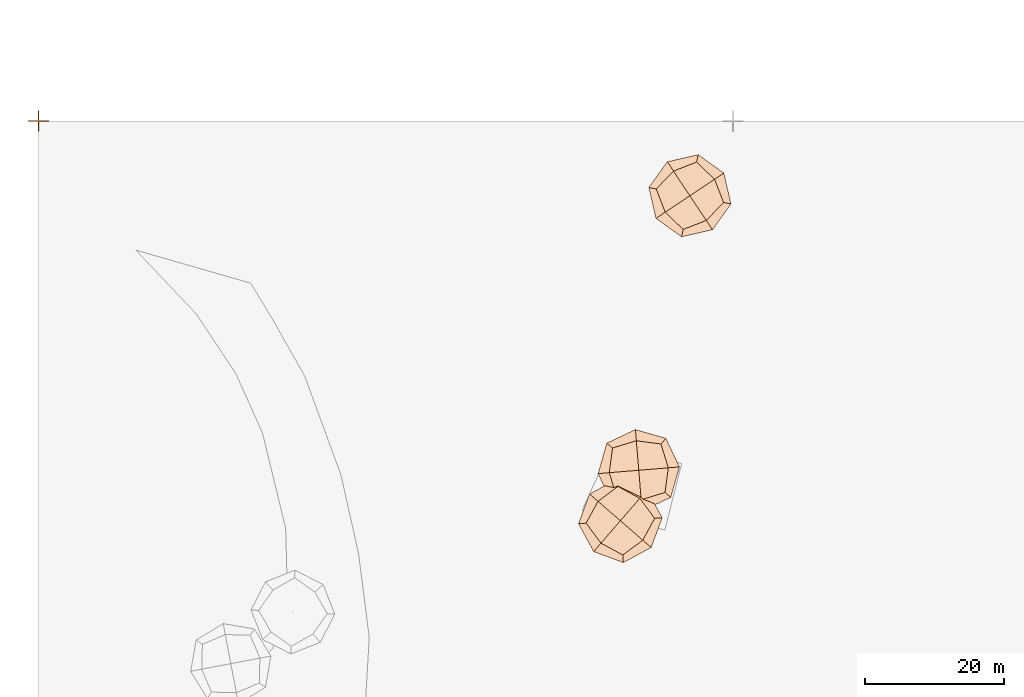
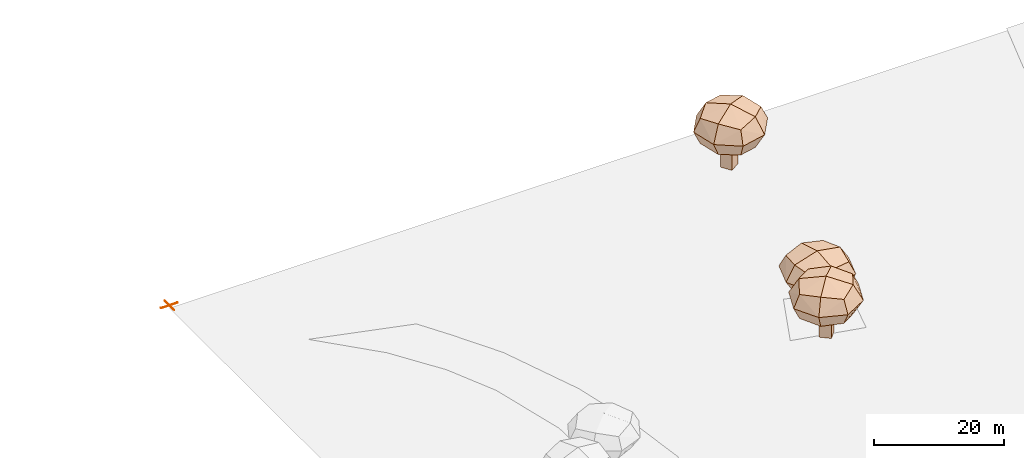
# Not in any storey, part 73 of 92: 3 geographic elements, 1 proxy.
"""IFC4 model written with IfcOpenShell, lengths in metres."""

from ifc_helpers import new_model, si_unit, origin_with_axes, place, context, subcontext, project, spatial, triangles, material, element, save


model = new_model("IFC4")

# Units and contexts
model_context = context("Model", 3, precision=1e-05, world=origin_with_axes())
body_context = subcontext(model_context, "Body", "Model", "MODEL_VIEW")
ifc_project = project(units=[si_unit("VOLUMEUNIT", "CUBIC_METRE"), si_unit("LENGTHUNIT", "METRE"), si_unit("AREAUNIT", "SQUARE_METRE")], contexts=[model_context])

# Site
site_placement = place(None, origin_with_axes())
site = spatial("IfcSite", under=ifc_project, at=site_placement)

# Proxy
proxy_placement = place(site_placement, origin_with_axes())
element("IfcBuildingElementProxy", 1, at=proxy_placement, inside=site, Name="CP1_Origin", ObjectType="Survey Control Point", context=body_context, shape_type="Tessellation", body=[
    triangles([(-1.5, -0.075, 0.0), (1.5, -0.075, 0.0), (1.5, 0.075, 0.0), (-1.5, 0.075, 0.0), (-0.075, -1.5, 0.0), (0.075, -1.5, 0.0), (0.075, 1.5, 0.0), (-0.075, 1.5, 0.0)], [[1, 2, 3], [1, 3, 4], [5, 6, 7], [5, 7, 8]], closed=False),
])

# Geographic elements
ifc_material = material(Name="tree")
geographic_element_1_placement = place(site_placement, origin_with_axes())
element("IfcGeographicElement", 2, at=geographic_element_1_placement, inside=site, material=ifc_material, Name="cw_instances_tree_0", context=body_context, shape_type="Tessellation", body=[
    triangles([(92.274878091013, -10.302522398242207, 6.749162418536442), (92.274878091013, -10.302522398242207, 6.749162418536442), (92.274878091013, -10.302522398242207, 6.749162418536442), (92.274878091013, -10.302522398242207, 0.0), (92.274878091013, -10.302522398242207, 0.0), (92.274878091013, -10.302522398242207, 0.0), (93.93964639189818, -9.19412422774216, 6.749162418536442), (93.93964639189818, -9.19412422774216, 6.749162418536442), (93.93964639189818, -9.19412422774216, 6.749162418536442), (93.93964639189818, -9.19412422774216, 0.0), (93.93964639189818, -9.19412422774216, 0.0), (93.93964639189818, -9.19412422774216, 0.0), (93.38327626151303, -11.967290699127393, 6.749162418536442), (93.38327626151303, -11.967290699127393, 6.749162418536442), (93.38327626151303, -11.967290699127393, 6.749162418536442), (93.38327626151303, -11.967290699127393, 0.0), (93.38327626151303, -11.967290699127393, 0.0), (93.38327626151303, -11.967290699127393, 0.0), (95.04804456239822, -10.858892528627347, 6.749162418536442), (95.04804456239822, -10.858892528627347, 6.749162418536442), (95.04804456239822, -10.858892528627347, 6.749162418536442), (95.04804456239822, -10.858892528627347, 0.0), (95.04804456239822, -10.858892528627347, 0.0), (95.04804456239822, -10.858892528627347, 0.0), (88.94627614886336, -9.814113544850345, 10.05331763230322), (88.94627614886336, -9.814113544850345, 10.05331763230322), (88.94627614886336, -9.814113544850345, 10.05331763230322), (88.94627614886336, -9.814113544850345, 10.05331763230322), (88.94627614886336, -9.814113544850345, 10.05331763230322), (88.94627614886336, -9.814113544850345, 10.05331763230322), (88.9462756163112, -9.81411361109371, 5.328904128304269), (88.9462756163112, -9.81411361109371, 5.328904128304269), (88.9462756163112, -9.81411361109371, 5.328904128304269), (88.9462756163112, -9.81411361109371, 5.328904128304269), (88.9462756163112, -9.81411361109371, 5.328904128304269), (88.9462756163112, -9.81411361109371, 5.328904128304269), (94.7729636788722, -5.9347206738404585, 10.05331763230322), (94.7729636788722, -5.9347206738404585, 10.05331763230322), (94.7729636788722, -5.9347206738404585, 10.05331763230322), (94.7729636788722, -5.9347206738404585, 10.05331763230322), (94.7729636788722, -5.9347206738404585, 10.05331763230322), (94.7729636788722, -5.9347206738404585, 10.05331763230322), (94.7729636788722, -5.9347206738404585, 5.328904128304269), (94.7729636788722, -5.9347206738404585, 5.328904128304269), (94.7729636788722, -5.9347206738404585, 5.328904128304269), (94.7729636788722, -5.9347206738404585, 5.328904128304269), (94.7729636788722, -5.9347206738404585, 5.328904128304269), (94.7729636788722, -5.9347206738404585, 5.328904128304269), (92.82566895258779, -15.64080227297131, 10.05331763230322), (92.82566895258779, -15.64080227297131, 10.05331763230322), (92.82566895258779, -15.64080227297131, 10.05331763230322), (92.82566895258779, -15.64080227297131, 10.05331763230322), (92.82566895258779, -15.64080227297131, 10.05331763230322), (92.82566895258779, -15.64080227297131, 10.05331763230322), (92.82566868657223, -15.640801873426918, 5.328904128304269), (92.82566868657223, -15.640801873426918, 5.328904128304269), (92.82566868657223, -15.640801873426918, 5.328904128304269), (92.82566868657223, -15.640801873426918, 5.328904128304269), (92.82566868657223, -15.640801873426918, 5.328904128304269), (92.82566868657223, -15.640801873426918, 5.328904128304269), (98.652357214921, -11.76140920271028, 10.05331763230322), (98.652357214921, -11.76140920271028, 10.05331763230322), (98.652357214921, -11.76140920271028, 10.05331763230322), (98.652357214921, -11.76140920271028, 10.05331763230322), (98.652357214921, -11.76140920271028, 10.05331763230322), (98.652357214921, -11.76140920271028, 10.05331763230322), (98.6523570151488, -11.76140933571806, 5.328904128304269), (98.6523570151488, -11.76140933571806, 5.328904128304269), (98.6523570151488, -11.76140933571806, 5.328904128304269), (98.6523570151488, -11.76140933571806, 5.328904128304269), (98.6523570151488, -11.76140933571806, 5.328904128304269), (98.6523570151488, -11.76140933571806, 5.328904128304269), (96.16406989531386, -14.339523496722784, 4.811260820074589), (96.16406989531386, -14.339523496722784, 4.811260820074589), (96.16406989531386, -14.339523496722784, 4.811260820074589), (96.16406989531386, -14.339523496722784, 4.811260820074589), (90.2475546893059, -13.152514584506985, 4.811260820074589), (90.2475546893059, -13.152514584506985, 4.811260820074589), (90.2475546893059, -13.152514584506985, 4.811260820074589), (90.2475546893059, -13.152514584506985, 4.811260820074589), (87.88280150196444, -9.600752906727205, 7.6911112852535135), (87.88280150196444, -9.600752906727205, 7.6911112852535135), (87.88280150196444, -9.600752906727205, 7.6911112852535135), (87.88280150196444, -9.600752906727205, 7.6911112852535135), (99.71583158974133, -11.974770298297335, 7.6911112852535135), (99.71583158974133, -11.974770298297335, 7.6911112852535135), (99.71583158974133, -11.974770298297335, 7.6911112852535135), (99.71583158974133, -11.974770298297335, 7.6911112852535135), (94.98632504653786, -4.871245841556212, 7.6911112852535135), (94.98632504653786, -4.871245841556212, 7.6911112852535135), (94.98632504653786, -4.871245841556212, 7.6911112852535135), (94.98632504653786, -4.871245841556212, 7.6911112852535135), (92.61230790989931, -16.704276312229815, 7.6911112852535135), (92.61230790989931, -16.704276312229815, 7.6911112852535135), (92.61230790989931, -16.704276312229815, 7.6911112852535135), (92.61230790989931, -16.704276312229815, 7.6911112852535135), (97.3510784943529, -8.423007910556542, 10.57096053558313), (97.3510784943529, -8.423007910556542, 10.57096053558313), (97.3510784943529, -8.423007910556542, 10.57096053558313), (97.3510784943529, -8.423007910556542, 10.57096053558313), (91.43456287765143, -7.2359993558751405, 10.570962121636393), (91.43456287765143, -7.2359993558751405, 10.570962121636393), (91.43456287765143, -7.2359993558751405, 10.570962121636393), (91.43456287765143, -7.2359993558751405, 10.570962121636393), (97.3510781308423, -8.423008212649322, 4.811260820074589), (97.3510781308423, -8.423008212649322, 4.811260820074589), (97.3510781308423, -8.423008212649322, 4.811260820074589), (97.3510781308423, -8.423008212649322, 4.811260820074589), (96.1640698620185, -14.339523518890747, 10.57096053558313), (96.1640698620185, -14.339523518890747, 10.57096053558313), (96.1640698620185, -14.339523518890747, 10.57096053558313), (96.1640698620185, -14.339523518890747, 10.57096053558313), (90.24755467267993, -13.152514559535462, 10.570962121636393), (90.24755467267993, -13.152514559535462, 10.570962121636393), (90.24755467267993, -13.152514559535462, 10.570962121636393), (90.24755467267993, -13.152514559535462, 10.570962121636393), (91.43456318806805, -7.235999713843746, 4.811260820074589), (91.43456318806805, -7.235999713843746, 4.811260820074589), (91.43456318806805, -7.235999713843746, 4.811260820074589), (91.43456318806805, -7.235999713843746, 4.811260820074589), (93.7993163115355, -10.78776153026014, 11.657286177333468), (93.7993163115355, -10.78776153026014, 11.657286177333468), (93.7993163115355, -10.78776153026014, 11.657286177333468), (93.7993163115355, -10.78776153026014, 11.657286177333468), (93.7993163115355, -10.78776153026014, 11.657286177333468), (93.7993163115355, -10.78776153026014, 11.657286177333468), (93.7993163115355, -10.78776153026014, 11.657286177333468), (93.7993163115355, -10.78776153026014, 11.657286177333468), (98.6908570869542, -7.530986996820504, 7.6911112852535135), (98.6908570869542, -7.530986996820504, 7.6911112852535135), (98.6908570869542, -7.530986996820504, 7.6911112852535135), (98.6908570869542, -7.530986996820504, 7.6911112852535135), (98.6908570869542, -7.530986996820504, 7.6911112852535135), (98.6908570869542, -7.530986996820504, 7.6911112852535135), (98.6908570869542, -7.530986996820504, 7.6911112852535135), (98.6908570869542, -7.530986996820504, 7.6911112852535135), (97.05609078407838, -15.679302105950047, 7.6911112852535135), (97.05609078407838, -15.679302105950047, 7.6911112852535135), (97.05609078407838, -15.679302105950047, 7.6911112852535135), (97.05609078407838, -15.679302105950047, 7.6911112852535135), (97.05609078407838, -15.679302105950047, 7.6911112852535135), (97.05609078407838, -15.679302105950047, 7.6911112852535135), (97.05609078407838, -15.679302105950047, 7.6911112852535135), (97.05609078407838, -15.679302105950047, 7.6911112852535135), (93.79931623394764, -10.787761413726358, 3.724937169327284), (93.79931623394764, -10.787761413726358, 3.724937169327284), (93.79931623394764, -10.787761413726358, 3.724937169327284), (93.79931623394764, -10.787761413726358, 3.724937169327284), (93.79931623394764, -10.787761413726358, 3.724937169327284), (93.79931623394764, -10.787761413726358, 3.724937169327284), (93.79931623394764, -10.787761413726358, 3.724937169327284), (93.79931623394764, -10.787761413726358, 3.724937169327284), (90.54254216612208, -5.896221193288338, 7.6911112852535135), (90.54254216612208, -5.896221193288338, 7.6911112852535135), (90.54254216612208, -5.896221193288338, 7.6911112852535135), (90.54254216612208, -5.896221193288338, 7.6911112852535135), (90.54254216612208, -5.896221193288338, 7.6911112852535135), (90.54254216612208, -5.896221193288338, 7.6911112852535135), (90.54254216612208, -5.896221193288338, 7.6911112852535135), (90.54254216612208, -5.896221193288338, 7.6911112852535135), (88.90777572487018, -14.044535805877793, 7.6911112852535135), (88.90777572487018, -14.044535805877793, 7.6911112852535135), (88.90777572487018, -14.044535805877793, 7.6911112852535135), (88.90777572487018, -14.044535805877793, 7.6911112852535135), (88.90777572487018, -14.044535805877793, 7.6911112852535135), (88.90777572487018, -14.044535805877793, 7.6911112852535135), (88.90777572487018, -14.044535805877793, 7.6911112852535135), (88.90777572487018, -14.044535805877793, 7.6911112852535135)], [[15, 8, 2], [7, 24, 11], [19, 16, 22], [4, 23, 17], [3, 12, 6], [14, 5, 18], [26, 127, 101], [54, 123, 114], [124, 66, 98], [128, 38, 102], [45, 133, 108], [40, 135, 89], [130, 63, 88], [131, 70, 105], [68, 141, 73], [61, 140, 86], [137, 49, 93], [142, 56, 74], [59, 145, 75], [31, 149, 79], [150, 43, 107], [146, 71, 76], [35, 154, 120], [30, 157, 83], [158, 42, 91], [153, 47, 119], [58, 164, 77], [51, 162, 96], [167, 28, 81], [165, 33, 80], [15, 21, 8], [7, 20, 24], [19, 13, 16], [4, 10, 23], [3, 9, 12], [14, 1, 5], [25, 115, 126], [53, 111, 121], [122, 112, 65], [125, 99, 37], [46, 90, 136], [39, 100, 134], [132, 97, 64], [129, 87, 69], [67, 85, 138], [62, 110, 144], [143, 109, 50], [139, 94, 55], [60, 78, 147], [32, 117, 151], [152, 118, 44], [148, 106, 72], [36, 84, 160], [29, 104, 156], [155, 103, 41], [159, 92, 48], [57, 95, 161], [52, 113, 163], [166, 116, 27], [168, 82, 34]], closed=True),
])
geographic_element_2_placement = place(site_placement, origin_with_axes())
element("IfcGeographicElement", 3, at=geographic_element_2_placement, inside=site, material=ifc_material, Name="cw_instances_tree_63", context=body_context, shape_type="Tessellation", body=[
    triangles([(83.85068214677291, -55.99029793161618, 6.435480642457017), (83.85068214677291, -55.99029793161618, 6.435480642457017), (83.85068214677291, -55.99029793161618, 6.435480642457017), (83.85068214677291, -55.99029793161618, 0.0), (83.85068214677291, -55.99029793161618, 0.0), (83.85068214677291, -55.99029793161618, 0.0), (85.36123295008736, -57.301113048482826, 6.435480642457017), (85.36123295008736, -57.301113048482826, 6.435480642457017), (85.36123295008736, -57.301113048482826, 6.435480642457017), (85.36123295008736, -57.301113048482826, 0.0), (85.36123295008736, -57.301113048482826, 0.0), (85.36123295008736, -57.301113048482826, 0.0), (82.53986702990628, -57.50084873493062, 6.435480642457017), (82.53986702990628, -57.50084873493062, 6.435480642457017), (82.53986702990628, -57.50084873493062, 6.435480642457017), (82.53986702990628, -57.50084873493062, 0.0), (82.53986702990628, -57.50084873493062, 0.0), (82.53986702990628, -57.50084873493062, 0.0), (84.0504178332207, -58.81166385179726, 6.435480642457017), (84.0504178332207, -58.81166385179726, 6.435480642457017), (84.0504178332207, -58.81166385179726, 6.435480642457017), (84.0504178332207, -58.81166385179726, 0.0), (84.0504178332207, -58.81166385179726, 0.0), (84.0504178332207, -58.81166385179726, 0.0), (83.43798136130964, -52.6514639796156, 9.586068167135462), (83.43798136130964, -52.6514639796156, 9.586068167135462), (83.43798136130964, -52.6514639796156, 9.586068167135462), (83.43798136130964, -52.6514639796156, 9.586068167135462), (83.43798136130964, -52.6514639796156, 9.586068167135462), (83.43798136130964, -52.6514639796156, 9.586068167135462), (83.43798115607527, -52.65146348375388, 5.08123189760902), (83.43798115607527, -52.65146348375388, 5.08123189760902), (83.43798115607527, -52.65146348375388, 5.08123189760902), (83.43798115607527, -52.65146348375388, 5.08123189760902), (83.43798115607527, -52.65146348375388, 5.08123189760902), (83.43798115607527, -52.65146348375388, 5.08123189760902), (88.72490806889806, -57.23931561285213, 9.586068167135462), (88.72490806889806, -57.23931561285213, 9.586068167135462), (88.72490806889806, -57.23931561285213, 9.586068167135462), (88.72490806889806, -57.23931561285213, 9.586068167135462), (88.72490806889806, -57.23931561285213, 9.586068167135462), (88.72490806889806, -57.23931561285213, 9.586068167135462), (88.72490806889806, -57.23931561285213, 5.08123189760902), (88.72490806889806, -57.23931561285213, 5.08123189760902), (88.72490806889806, -57.23931561285213, 5.08123189760902), (88.72490806889806, -57.23931561285213, 5.08123189760902), (88.72490806889806, -57.23931561285213, 5.08123189760902), (88.72490806889806, -57.23931561285213, 5.08123189760902), (78.85012855508357, -57.938390940374966, 9.586068167135462), (78.85012855508357, -57.938390940374966, 9.586068167135462), (78.85012855508357, -57.938390940374966, 9.586068167135462), (78.85012855508357, -57.938390940374966, 9.586068167135462), (78.85012855508357, -57.938390940374966, 9.586068167135462), (78.85012855508357, -57.938390940374966, 9.586068167135462), (78.8501288696792, -57.938390577842775, 5.08123189760902), (78.8501288696792, -57.938390577842775, 5.08123189760902), (78.8501288696792, -57.938390577842775, 5.08123189760902), (78.8501288696792, -57.938390577842775, 5.08123189760902), (78.8501288696792, -57.938390577842775, 5.08123189760902), (78.8501288696792, -57.938390577842775, 5.08123189760902), (84.13705564917247, -62.52624322677104, 9.586068167135462), (84.13705564917247, -62.52624322677104, 9.586068167135462), (84.13705564917247, -62.52624322677104, 9.586068167135462), (84.13705564917247, -62.52624322677104, 9.586068167135462), (84.13705564917247, -62.52624322677104, 9.586068167135462), (84.13705564917247, -62.52624322677104, 9.586068167135462), (84.13705546790638, -62.526243069473225, 5.08123189760902), (84.13705546790638, -62.526243069473225, 5.08123189760902), (84.13705546790638, -62.526243069473225, 5.08123189760902), (84.13705546790638, -62.526243069473225, 5.08123189760902), (84.13705546790638, -62.526243069473225, 5.08123189760902), (84.13705546790638, -62.526243069473225, 5.08123189760902), (80.99091095376036, -60.81159438416813, 4.587647170612347), (80.99091095376036, -60.81159438416813, 4.587647170612347), (80.99091095376036, -60.81159438416813, 4.587647170612347), (80.99091095376036, -60.81159438416813, 4.587647170612347), (80.56477776146801, -54.79224617667673, 4.587647170612347), (80.56477776146801, -54.79224617667673, 4.587647170612347), (80.56477776146801, -54.79224617667673, 4.587647170612347), (80.56477776146801, -54.79224617667673, 4.587647170612347), (83.36138489067983, -51.56950553901625, 7.3336504185011036), (83.36138489067983, -51.56950553901625, 7.3336504185011036), (83.36138489067983, -51.56950553901625, 7.3336504185011036), (83.36138489067983, -51.56950553901625, 7.3336504185011036), (84.21365160652634, -63.6082015264881, 7.3336504185011036), (84.21365160652634, -63.6082015264881, 7.3336504185011036), (84.21365160652634, -63.6082015264881, 7.3336504185011036), (84.21365160652634, -63.6082015264881, 7.3336504185011036), (89.80686688189107, -57.162719796380536, 7.3336504185011036), (89.80686688189107, -57.162719796380536, 7.3336504185011036), (89.80686688189107, -57.162719796380536, 7.3336504185011036), (89.80686688189107, -57.162719796380536, 7.3336504185011036), (77.76817059293174, -58.01498685965374, 7.3336504185011036), (77.76817059293174, -58.01498685965374, 7.3336504185011036), (77.76817059293174, -58.01498685965374, 7.3336504185011036), (77.76817059293174, -58.01498685965374, 7.3336504185011036), (87.01025944463768, -60.385460789020456, 10.079652508003273), (87.01025944463768, -60.385460789020456, 10.079652508003273), (87.01025944463768, -60.385460789020456, 10.079652508003273), (87.01025944463768, -60.385460789020456, 10.079652508003273), (86.5841257986181, -54.366112280478255, 10.079654020341316), (86.5841257986181, -54.366112280478255, 10.079654020341316), (86.5841257986181, -54.366112280478255, 10.079654020341316), (86.5841257986181, -54.366112280478255, 10.079654020341316), (87.01025905688788, -60.385460518742676, 4.587647170612347), (87.01025905688788, -60.385460518742676, 4.587647170612347), (87.01025905688788, -60.385460518742676, 4.587647170612347), (87.01025905688788, -60.385460518742676, 4.587647170612347), (80.99091092354934, -60.811594357951826, 10.079652508003273), (80.99091092354934, -60.811594357951826, 10.079652508003273), (80.99091092354934, -60.811594357951826, 10.079652508003273), (80.99091092354934, -60.811594357951826, 10.079652508003273), (80.56477778113023, -54.79224615401847, 10.079654020341316), (80.56477778113023, -54.79224615401847, 10.079654020341316), (80.56477778113023, -54.79224615401847, 10.079654020341316), (80.56477778113023, -54.79224615401847, 10.079654020341316), (86.58412553589307, -54.36611267478215, 4.587647170612347), (86.58412553589307, -54.36611267478215, 4.587647170612347), (86.58412553589307, -54.36611267478215, 4.587647170612347), (86.58412553589307, -54.36611267478215, 4.587647170612347), (83.78751825606284, -57.58885328766168, 11.115488839292068), (83.78751825606284, -57.58885328766168, 11.115488839292068), (83.78751825606284, -57.58885328766168, 11.115488839292068), (83.78751825606284, -57.58885328766168, 11.115488839292068), (83.78751825606284, -57.58885328766168, 11.115488839292068), (83.78751825606284, -57.58885328766168, 11.115488839292068), (83.78751825606284, -57.58885328766168, 11.115488839292068), (83.78751825606284, -57.58885328766168, 11.115488839292068), (88.22592629043315, -61.44038358608614, 7.3336504185011036), (88.22592629043315, -61.44038358608614, 7.3336504185011036), (88.22592629043315, -61.44038358608614, 7.3336504185011036), (88.22592629043315, -61.44038358608614, 7.3336504185011036), (88.22592629043315, -61.44038358608614, 7.3336504185011036), (88.22592629043315, -61.44038358608614, 7.3336504185011036), (88.22592629043315, -61.44038358608614, 7.3336504185011036), (88.22592629043315, -61.44038358608614, 7.3336504185011036), (79.93598813403642, -62.02726121030136, 7.3336504185011036), (79.93598813403642, -62.02726121030136, 7.3336504185011036), (79.93598813403642, -62.02726121030136, 7.3336504185011036), (79.93598813403642, -62.02726121030136, 7.3336504185011036), (79.93598813403642, -62.02726121030136, 7.3336504185011036), (79.93598813403642, -62.02726121030136, 7.3336504185011036), (79.93598813403642, -62.02726121030136, 7.3336504185011036), (79.93598813403642, -62.02726121030136, 7.3336504185011036), (83.7875183478199, -57.58885318192312, 3.551812737790455), (83.7875183478199, -57.58885318192312, 3.551812737790455), (83.7875183478199, -57.58885318192312, 3.551812737790455), (83.7875183478199, -57.58885318192312, 3.551812737790455), (83.7875183478199, -57.58885318192312, 3.551812737790455), (83.7875183478199, -57.58885318192312, 3.551812737790455), (83.7875183478199, -57.58885318192312, 3.551812737790455), (83.7875183478199, -57.58885318192312, 3.551812737790455), (87.63904823477294, -53.150445743783706, 7.3336504185011036), (87.63904823477294, -53.150445743783706, 7.3336504185011036), (87.63904823477294, -53.150445743783706, 7.3336504185011036), (87.63904823477294, -53.150445743783706, 7.3336504185011036), (87.63904823477294, -53.150445743783706, 7.3336504185011036), (87.63904823477294, -53.150445743783706, 7.3336504185011036), (87.63904823477294, -53.150445743783706, 7.3336504185011036), (87.63904823477294, -53.150445743783706, 7.3336504185011036), (79.34911052036998, -53.737323102779186, 7.3336504185011036), (79.34911052036998, -53.737323102779186, 7.3336504185011036), (79.34911052036998, -53.737323102779186, 7.3336504185011036), (79.34911052036998, -53.737323102779186, 7.3336504185011036), (79.34911052036998, -53.737323102779186, 7.3336504185011036), (79.34911052036998, -53.737323102779186, 7.3336504185011036), (79.34911052036998, -53.737323102779186, 7.3336504185011036), (79.34911052036998, -53.737323102779186, 7.3336504185011036)], [[15, 8, 2], [7, 24, 11], [19, 16, 22], [4, 23, 17], [3, 12, 6], [14, 5, 18], [26, 127, 101], [54, 123, 114], [124, 66, 98], [128, 38, 102], [45, 133, 108], [40, 135, 89], [130, 63, 88], [131, 70, 105], [68, 141, 73], [61, 140, 86], [137, 49, 93], [142, 56, 74], [59, 145, 75], [31, 149, 79], [150, 43, 107], [146, 71, 76], [35, 154, 120], [30, 157, 83], [158, 42, 91], [153, 47, 119], [58, 164, 77], [51, 162, 96], [167, 28, 81], [165, 33, 80], [15, 21, 8], [7, 20, 24], [19, 13, 16], [4, 10, 23], [3, 9, 12], [14, 1, 5], [25, 115, 126], [53, 111, 121], [122, 112, 65], [125, 99, 37], [46, 90, 136], [39, 100, 134], [132, 97, 64], [129, 87, 69], [67, 85, 138], [62, 110, 144], [143, 109, 50], [139, 94, 55], [60, 78, 147], [32, 117, 151], [152, 118, 44], [148, 106, 72], [36, 84, 160], [29, 104, 156], [155, 103, 41], [159, 92, 48], [57, 95, 161], [52, 113, 163], [166, 116, 27], [168, 82, 34]], closed=True),
])
geographic_element_3_placement = place(site_placement, origin_with_axes())
element("IfcGeographicElement", 4, at=geographic_element_3_placement, inside=site, material=ifc_material, Name="cw_instances_tree_64", context=body_context, shape_type="Tessellation", body=[
    triangles([(87.59801395692567, -49.218886108406636, 6.105379025582397), (87.59801395692567, -49.218886108406636, 6.105379025582397), (87.59801395692567, -49.218886108406636, 6.105379025582397), (87.59801395692567, -49.218886108406636, 0.0), (87.59801395692567, -49.218886108406636, 0.0), (87.59801395692567, -49.218886108406636, 0.0), (87.76233868025686, -51.212124023283366, 6.105379025582397), (87.76233868025686, -51.212124023283366, 6.105379025582397), (87.76233868025686, -51.212124023283366, 6.105379025582397), (87.76233868025686, -51.212124023283366, 0.0), (87.76233868025686, -51.212124023283366, 0.0), (87.76233868025686, -51.212124023283366, 0.0), (85.60477604204894, -49.38321083173783, 6.105379025582397), (85.60477604204894, -49.38321083173783, 6.105379025582397), (85.60477604204894, -49.38321083173783, 6.105379025582397), (85.60477604204894, -49.38321083173783, 0.0), (85.60477604204894, -49.38321083173783, 0.0), (85.60477604204894, -49.38321083173783, 0.0), (85.76910076538013, -51.37644874661455, 6.105379025582397), (85.76910076538013, -51.37644874661455, 6.105379025582397), (85.76910076538013, -51.37644874661455, 6.105379025582397), (85.76910076538013, -51.37644874661455, 0.0), (85.76910076538013, -51.37644874661455, 0.0), (85.76910076538013, -51.37644874661455, 0.0), (89.63624843385455, -46.54237077790462, 9.094360278129429), (89.63624843385455, -46.54237077790462, 9.094360278129429), (89.63624843385455, -46.54237077790462, 9.094360278129429), (89.63624843385455, -46.54237077790462, 9.094360278129429), (89.63624843385455, -46.54237077790462, 9.094360278129429), (89.63624843385455, -46.54237077790462, 9.094360278129429), (89.63624863360516, -46.54237027980856, 4.820595131172373), (89.63624863360516, -46.54237027980856, 4.820595131172373), (89.63624863360516, -46.54237027980856, 4.820595131172373), (89.63624863360516, -46.54237027980856, 4.820595131172373), (89.63624863360516, -46.54237027980856, 4.820595131172373), (89.63624863360516, -46.54237027980856, 4.820595131172373), (90.21138506749112, -53.51870179590055, 9.094360278129429), (90.21138506749112, -53.51870179590055, 9.094360278129429), (90.21138506749112, -53.51870179590055, 9.094360278129429), (90.21138506749112, -53.51870179590055, 9.094360278129429), (90.21138506749112, -53.51870179590055, 9.094360278129429), (90.21138506749112, -53.51870179590055, 9.094360278129429), (90.21138506749112, -53.51870179590055, 4.820595131172373), (90.21138506749112, -53.51870179590055, 4.820595131172373), (90.21138506749112, -53.51870179590055, 4.820595131172373), (90.21138506749112, -53.51870179590055, 4.820595131172373), (90.21138506749112, -53.51870179590055, 4.820595131172373), (90.21138506749112, -53.51870179590055, 4.820595131172373), (82.65991639994753, -47.11750677285141, 9.094360278129429), (82.65991639994753, -47.11750677285141, 9.094360278129429), (82.65991639994753, -47.11750677285141, 9.094360278129429), (82.65991639994753, -47.11750677285141, 9.094360278129429), (82.65991639994753, -47.11750677285141, 9.094360278129429), (82.65991639994753, -47.11750677285141, 9.094360278129429), (82.65991687832462, -47.11750673341347, 4.820595131172373), (82.65991687832462, -47.11750673341347, 4.820595131172373), (82.65991687832462, -47.11750673341347, 4.820595131172373), (82.65991687832462, -47.11750673341347, 4.820595131172373), (82.65991687832462, -47.11750673341347, 4.820595131172373), (82.65991687832462, -47.11750673341347, 4.820595131172373), (83.23505285355245, -54.09383852813195, 9.094360278129429), (83.23505285355245, -54.09383852813195, 9.094360278129429), (83.23505285355245, -54.09383852813195, 9.094360278129429), (83.23505285355245, -54.09383852813195, 9.094360278129429), (83.23505285355245, -54.09383852813195, 9.094360278129429), (83.23505285355245, -54.09383852813195, 9.094360278129429), (83.23505283383348, -54.093838288943395, 4.820595131172373), (83.23505283383348, -54.093838288943395, 4.820595131172373), (83.23505283383348, -54.093838288943395, 4.820595131172373), (83.23505283383348, -54.093838288943395, 4.820595131172373), (83.23505283383348, -54.093838288943395, 4.820595131172373), (83.23505283383348, -54.093838288943395, 4.820595131172373), (82.18310288283065, -50.66868913620644, 4.352328344745872), (82.18310288283065, -50.66868913620644, 4.352328344745872), (82.18310288283065, -50.66868913620644, 4.352328344745872), (82.18310288283065, -50.66868913620644, 4.352328344745872), (86.08506609978987, -46.06555700752489, 4.352328344745872), (86.08506609978987, -46.06555700752489, 4.352328344745872), (86.08506609978987, -46.06555700752489, 4.352328344745872), (86.08506609978987, -46.06555700752489, 4.352328344745872), (90.33761345847789, -45.714972331729975, 6.957478070973664), (90.33761345847789, -45.714972331729975, 6.957478070973664), (90.33761345847789, -45.714972331729975, 6.957478070973664), (90.33761345847789, -45.714972331729975, 6.957478070973664), (82.5336875602688, -54.92123651482684, 6.957478070973664), (82.5336875602688, -54.92123651482684, 6.957478070973664), (82.5336875602688, -54.92123651482684, 6.957478070973664), (82.5336875602688, -54.92123651482684, 6.957478070973664), (91.0387833228463, -54.22006754866394, 6.957478070973664), (91.0387833228463, -54.22006754866394, 6.957478070973664), (91.0387833228463, -54.22006754866394, 6.957478070973664), (91.0387833228463, -54.22006754866394, 6.957478070973664), (81.83251868130472, -46.41614168824954, 6.957478070973664), (81.83251868130472, -46.41614168824954, 6.957478070973664), (81.83251868130472, -46.41614168824954, 6.957478070973664), (81.83251868130472, -46.41614168824954, 6.957478070973664), (86.78623549574738, -54.57065226307516, 9.562626698233165), (86.78623549574738, -54.57065226307516, 9.562626698233165), (86.78623549574738, -54.57065226307516, 9.562626698233165), (86.78623549574738, -54.57065226307516, 9.562626698233165), (90.6881985985756, -49.967519601970736, 9.562628132997322), (90.6881985985756, -49.967519601970736, 9.562628132997322), (90.6881985985756, -49.967519601970736, 9.562628132997322), (90.6881985985756, -49.967519601970736, 9.562628132997322), (86.78623540730011, -54.570651798772374, 4.352328344745872), (86.78623540730011, -54.570651798772374, 4.352328344745872), (86.78623540730011, -54.570651798772374, 4.352328344745872), (86.78623540730011, -54.570651798772374, 4.352328344745872), (82.18310287954415, -50.66868909634168, 9.562626698233165), (82.18310287954415, -50.66868909634168, 9.562626698233165), (82.18310287954415, -50.66868909634168, 9.562626698233165), (82.18310287954415, -50.66868909634168, 9.562626698233165), (86.08506612968844, -46.065557005060015, 9.562628132997322), (86.08506612968844, -46.065557005060015, 9.562628132997322), (86.08506612968844, -46.065557005060015, 9.562628132997322), (86.08506612968844, -46.065557005060015, 9.562628132997322), (90.68819813509442, -49.96751970038419, 4.352328344745872), (90.68819813509442, -49.96751970038419, 4.352328344745872), (90.68819813509442, -49.96751970038419, 4.352328344745872), (90.68819813509442, -49.96751970038419, 4.352328344745872), (86.43565068599578, -50.31810425319162, 10.545330829027087), (86.43565068599578, -50.31810425319162, 10.545330829027087), (86.43565068599578, -50.31810425319162, 10.545330829027087), (86.43565068599578, -50.31810425319162, 10.545330829027087), (86.43565068599578, -50.31810425319162, 10.545330829027087), (86.43565068599578, -50.31810425319162, 10.545330829027087), (86.43565068599578, -50.31810425319162, 10.545330829027087), (86.43565068599578, -50.31810425319162, 10.545330829027087), (86.91848137431029, -56.17477788637849, 6.957478070973664), (86.91848137431029, -56.17477788637849, 6.957478070973664), (86.91848137431029, -56.17477788637849, 6.957478070973664), (86.91848137431029, -56.17477788637849, 6.957478070973664), (86.91848137431029, -56.17477788637849, 6.957478070973664), (86.91848137431029, -56.17477788637849, 6.957478070973664), (86.91848137431029, -56.17477788637849, 6.957478070973664), (86.91848137431029, -56.17477788637849, 6.957478070973664), (80.57897725706245, -50.80093498487079, 6.957478070973664), (80.57897725706245, -50.80093498487079, 6.957478070973664), (80.57897725706245, -50.80093498487079, 6.957478070973664), (80.57897725706245, -50.80093498487079, 6.957478070973664), (80.57897725706245, -50.80093498487079, 6.957478070973664), (80.57897725706245, -50.80093498487079, 6.957478070973664), (80.57897725706245, -50.80093498487079, 6.957478070973664), (80.57897725706245, -50.80093498487079, 6.957478070973664), (86.43565082552244, -50.31810424168889, 3.3696260150388717), (86.43565082552244, -50.31810424168889, 3.3696260150388717), (86.43565082552244, -50.31810424168889, 3.3696260150388717), (86.43565082552244, -50.31810424168889, 3.3696260150388717), (86.43565082552244, -50.31810424168889, 3.3696260150388717), (86.43565082552244, -50.31810424168889, 3.3696260150388717), (86.43565082552244, -50.31810424168889, 3.3696260150388717), (86.43565082552244, -50.31810424168889, 3.3696260150388717), (92.29232374771665, -49.835273692260806, 6.957478070973664), (92.29232374771665, -49.835273692260806, 6.957478070973664), (92.29232374771665, -49.835273692260806, 6.957478070973664), (92.29232374771665, -49.835273692260806, 6.957478070973664), (92.29232374771665, -49.835273692260806, 6.957478070973664), (92.29232374771665, -49.835273692260806, 6.957478070973664), (92.29232374771665, -49.835273692260806, 6.957478070973664), (92.29232374771665, -49.835273692260806, 6.957478070973664), (85.95282013195808, -44.461430909952576, 6.957478070973664), (85.95282013195808, -44.461430909952576, 6.957478070973664), (85.95282013195808, -44.461430909952576, 6.957478070973664), (85.95282013195808, -44.461430909952576, 6.957478070973664), (85.95282013195808, -44.461430909952576, 6.957478070973664), (85.95282013195808, -44.461430909952576, 6.957478070973664), (85.95282013195808, -44.461430909952576, 6.957478070973664), (85.95282013195808, -44.461430909952576, 6.957478070973664)], [[15, 8, 2], [7, 24, 11], [19, 16, 22], [4, 23, 17], [3, 12, 6], [14, 5, 18], [26, 127, 101], [54, 123, 114], [124, 66, 98], [128, 38, 102], [45, 133, 108], [40, 135, 89], [130, 63, 88], [131, 70, 105], [68, 141, 73], [61, 140, 86], [137, 49, 93], [142, 56, 74], [59, 145, 75], [31, 149, 79], [150, 43, 107], [146, 71, 76], [35, 154, 120], [30, 157, 83], [158, 42, 91], [153, 47, 119], [58, 164, 77], [51, 162, 96], [167, 28, 81], [165, 33, 80], [15, 21, 8], [7, 20, 24], [19, 13, 16], [4, 10, 23], [3, 9, 12], [14, 1, 5], [25, 115, 126], [53, 111, 121], [122, 112, 65], [125, 99, 37], [46, 90, 136], [39, 100, 134], [132, 97, 64], [129, 87, 69], [67, 85, 138], [62, 110, 144], [143, 109, 50], [139, 94, 55], [60, 78, 147], [32, 117, 151], [152, 118, 44], [148, 106, 72], [36, 84, 160], [29, 104, 156], [155, 103, 41], [159, 92, 48], [57, 95, 161], [52, 113, 163], [166, 116, 27], [168, 82, 34]], closed=True),
])

save(model, "model.ifc")
